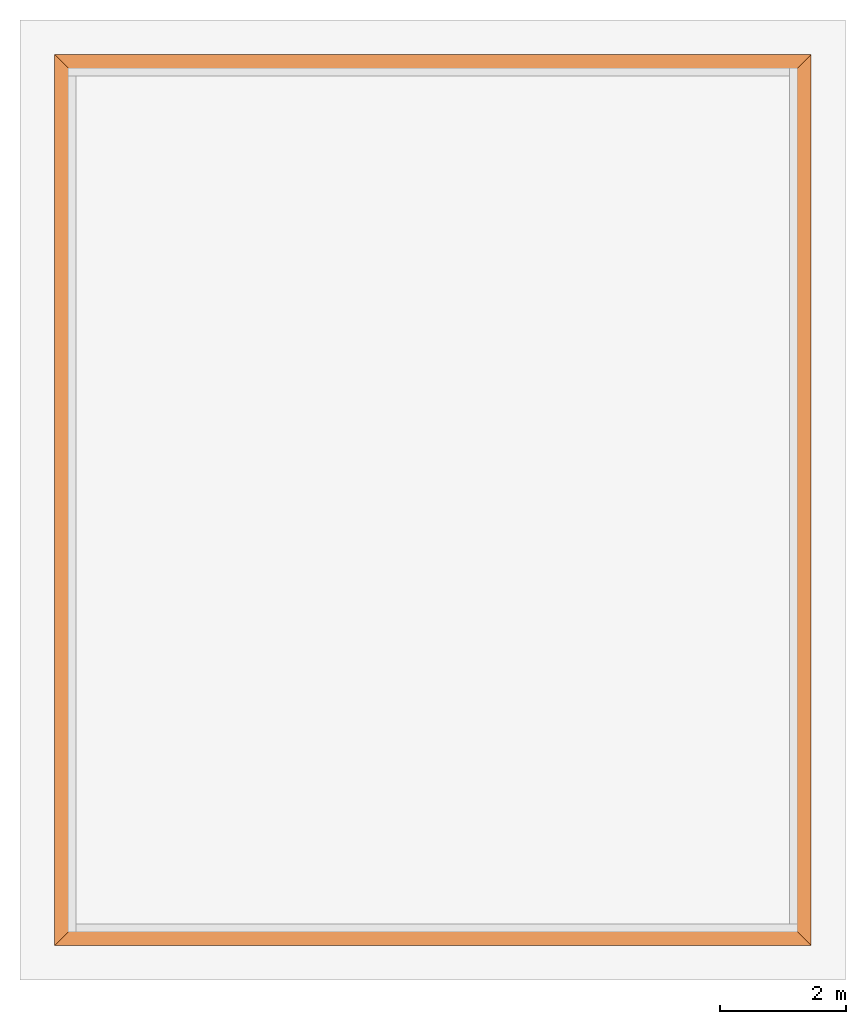
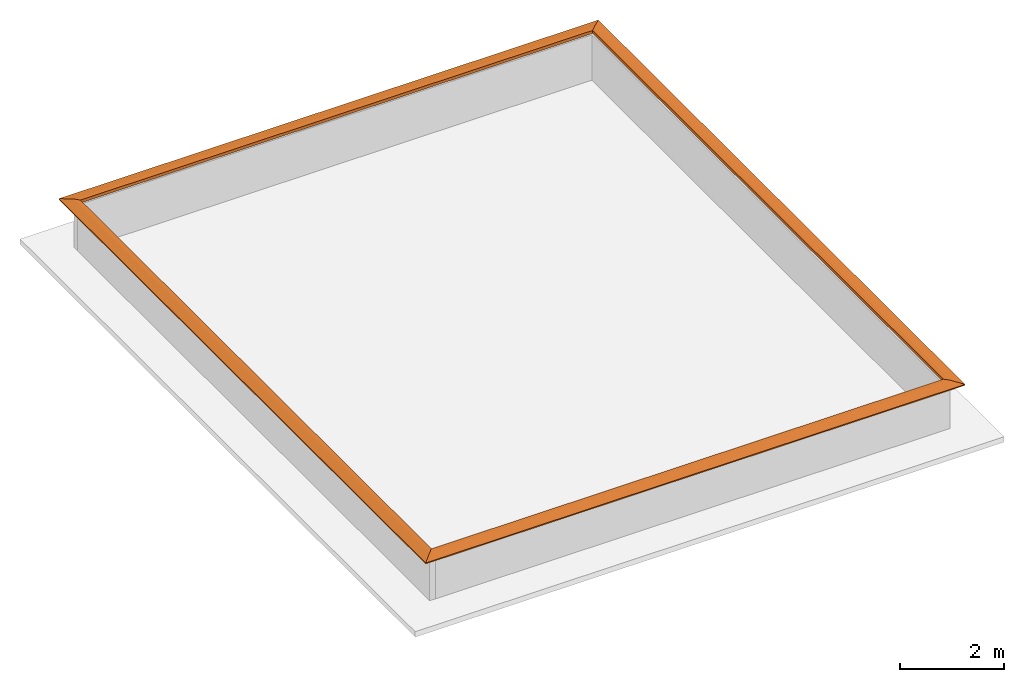
# One storey, part 2 of 2: 4 proxies.
"""IFC2X3 building model written with IfcOpenShell, lengths in feet."""

from ifc_helpers import new_model, entity, si_unit, converted_unit, derived_unit, direction, frame, origin, place, context, subcontext, project, spatial, faceted_brep, material, type_object, element, save


model = new_model("IFC2X3")

# Units and contexts
model_context = context("Model", 3, precision=0.0001, world=origin(), true_north=direction((6.123031769111886e-17, 1.0)))
body_context = subcontext(model_context, "Body", "Model", "MODEL_VIEW")
ifc_project = project(units=[converted_unit("LENGTHUNIT", "FOOT", entity("IfcLengthMeasure", 0.3048), si_unit("LENGTHUNIT", "METRE"), dimensions=[1, 0, 0, 0, 0, 0, 0]), converted_unit("AREAUNIT", "SQUARE FOOT", entity("IfcAreaMeasure", 0.09290304), si_unit("AREAUNIT", "SQUARE_METRE"), dimensions=[2, 0, 0, 0, 0, 0, 0]), converted_unit("VOLUMEUNIT", "CUBIC FOOT", entity("IfcVolumeMeasure", 0.028316846592000004), si_unit("VOLUMEUNIT", "CUBIC_METRE"), dimensions=[3, 0, 0, 0, 0, 0, 0]), converted_unit("PLANEANGLEUNIT", "DEGREE", entity("IfcPlaneAngleMeasure", 0.017453292519943278), si_unit("PLANEANGLEUNIT", "RADIAN"), dimensions=[0, 0, 0, 0, 0, 0, 0]), si_unit("MASSUNIT", "GRAM", prefix="KILO"), derived_unit("MASSDENSITYUNIT", [(si_unit("MASSUNIT", "GRAM", prefix="KILO"), 1), (si_unit("LENGTHUNIT", "METRE"), -3)]), derived_unit("IONCONCENTRATIONUNIT", [(si_unit("MASSUNIT", "GRAM", prefix="KILO"), 1), (si_unit("LENGTHUNIT", "METRE"), -3)]), derived_unit("MOMENTOFINERTIAUNIT", [(si_unit("LENGTHUNIT", "METRE"), 4)]), si_unit("TIMEUNIT", "SECOND"), si_unit("FREQUENCYUNIT", "HERTZ"), si_unit("THERMODYNAMICTEMPERATUREUNIT", "DEGREE_CELSIUS"), derived_unit("THERMALTRANSMITTANCEUNIT", [(si_unit("MASSUNIT", "GRAM", prefix="KILO"), 1), (si_unit("THERMODYNAMICTEMPERATUREUNIT", "KELVIN"), -1), (si_unit("TIMEUNIT", "SECOND"), -3)]), derived_unit("THERMALCONDUCTANCEUNIT", [(si_unit("MASSUNIT", "GRAM", prefix="KILO"), 1), (si_unit("THERMODYNAMICTEMPERATUREUNIT", "KELVIN"), -1), (si_unit("TIMEUNIT", "SECOND"), -3), (si_unit("LENGTHUNIT", "METRE"), 1)]), derived_unit("VOLUMETRICFLOWRATEUNIT", [(si_unit("LENGTHUNIT", "METRE"), 3), (si_unit("TIMEUNIT", "SECOND"), -1)]), derived_unit("MASSFLOWRATEUNIT", [(si_unit("MASSUNIT", "GRAM", prefix="KILO"), 1), (si_unit("TIMEUNIT", "SECOND"), -1)]), derived_unit("ROTATIONALFREQUENCYUNIT", [(si_unit("TIMEUNIT", "SECOND"), -1)]), si_unit("ELECTRICCURRENTUNIT", "AMPERE"), si_unit("ELECTRICVOLTAGEUNIT", "VOLT"), si_unit("POWERUNIT", "WATT"), converted_unit("FORCEUNIT", "KIP", entity("IfcForceMeasure", 2.088543423315013e-05), si_unit("FORCEUNIT", "NEWTON"), dimensions=[1, 1, -2, 0, 0, 0, 0]), si_unit("ILLUMINANCEUNIT", "LUX"), si_unit("LUMINOUSFLUXUNIT", "LUMEN"), si_unit("LUMINOUSINTENSITYUNIT", "CANDELA"), si_unit("ENERGYUNIT", "JOULE"), derived_unit("USERDEFINED", [(si_unit("MASSUNIT", "GRAM", prefix="KILO"), -1), (si_unit("LENGTHUNIT", "METRE"), -2), (si_unit("TIMEUNIT", "SECOND"), 3), (si_unit("LUMINOUSFLUXUNIT", "LUMEN"), 1)]), derived_unit("USERDEFINED", [(si_unit("MASSUNIT", "GRAM", prefix="KILO"), 1), (si_unit("TIMEUNIT", "SECOND"), -3), (si_unit("LENGTHUNIT", "METRE"), 3), (si_unit("ELECTRICCURRENTUNIT", "AMPERE"), -2)]), derived_unit("SOUNDPOWERUNIT", [(si_unit("MASSUNIT", "GRAM", prefix="KILO"), 1), (si_unit("TIMEUNIT", "SECOND"), -3), (si_unit("LENGTHUNIT", "METRE"), 2)]), derived_unit("SOUNDPRESSUREUNIT", [(si_unit("MASSUNIT", "GRAM", prefix="KILO"), 1), (si_unit("LENGTHUNIT", "METRE"), -1), (si_unit("TIMEUNIT", "SECOND"), -2)]), derived_unit("LINEARVELOCITYUNIT", [(si_unit("LENGTHUNIT", "METRE"), 1), (si_unit("TIMEUNIT", "SECOND"), -1)]), si_unit("PRESSUREUNIT", "PASCAL"), derived_unit("USERDEFINED", [(si_unit("MASSUNIT", "GRAM", prefix="KILO"), 1), (si_unit("LENGTHUNIT", "METRE"), -2), (si_unit("TIMEUNIT", "SECOND"), -2)]), derived_unit("LINEARFORCEUNIT", [(si_unit("MASSUNIT", "GRAM", prefix="KILO"), 1), (si_unit("TIMEUNIT", "SECOND"), -2)]), derived_unit("PLANARFORCEUNIT", [(si_unit("MASSUNIT", "GRAM", prefix="KILO"), 1), (si_unit("LENGTHUNIT", "METRE"), -1), (si_unit("TIMEUNIT", "SECOND"), -2)]), derived_unit("SPECIFICHEATCAPACITYUNIT", [(si_unit("THERMODYNAMICTEMPERATUREUNIT", "KELVIN"), -1), (si_unit("LENGTHUNIT", "METRE"), 2), (si_unit("TIMEUNIT", "SECOND"), -2)]), derived_unit("HEATFLUXDENSITYUNIT", [(si_unit("MASSUNIT", "GRAM", prefix="KILO"), 1), (si_unit("TIMEUNIT", "SECOND"), -3)]), derived_unit("HEATINGVALUEUNIT", [(si_unit("LENGTHUNIT", "METRE"), 2), (si_unit("TIMEUNIT", "SECOND"), -2)]), derived_unit("VAPORPERMEABILITYUNIT", [(si_unit("LENGTHUNIT", "METRE"), -1), (si_unit("TIMEUNIT", "SECOND"), 1)]), derived_unit("DYNAMICVISCOSITYUNIT", [(si_unit("MASSUNIT", "GRAM", prefix="KILO"), 1), (si_unit("TIMEUNIT", "SECOND"), -1), (si_unit("LENGTHUNIT", "METRE"), -1)]), derived_unit("THERMALEXPANSIONCOEFFICIENTUNIT", [(si_unit("THERMODYNAMICTEMPERATUREUNIT", "KELVIN"), -1)]), derived_unit("MODULUSOFELASTICITYUNIT", [(si_unit("MASSUNIT", "GRAM", prefix="KILO"), 1), (si_unit("LENGTHUNIT", "METRE"), -1), (si_unit("TIMEUNIT", "SECOND"), -2)]), derived_unit("ISOTHERMALMOISTURECAPACITYUNIT", [(si_unit("LENGTHUNIT", "METRE"), 3), (si_unit("MASSUNIT", "GRAM", prefix="KILO"), -1)]), derived_unit("MOISTUREDIFFUSIVITYUNIT", [(si_unit("TIMEUNIT", "SECOND"), -1), (si_unit("LENGTHUNIT", "METRE"), 2)]), derived_unit("MASSPERLENGTHUNIT", [(si_unit("MASSUNIT", "GRAM", prefix="KILO"), 1), (si_unit("LENGTHUNIT", "METRE"), -1)]), derived_unit("THERMALRESISTANCEUNIT", [(si_unit("MASSUNIT", "GRAM", prefix="KILO"), -1), (si_unit("TIMEUNIT", "SECOND"), 3), (si_unit("THERMODYNAMICTEMPERATUREUNIT", "KELVIN"), 1)]), derived_unit("ACCELERATIONUNIT", [(si_unit("LENGTHUNIT", "METRE"), 1), (si_unit("TIMEUNIT", "SECOND"), -2)]), derived_unit("ANGULARVELOCITYUNIT", [(si_unit("TIMEUNIT", "SECOND"), -1), (si_unit("PLANEANGLEUNIT", "RADIAN"), 1)]), derived_unit("LINEARSTIFFNESSUNIT", [(si_unit("MASSUNIT", "GRAM", prefix="KILO"), 1), (si_unit("TIMEUNIT", "SECOND"), -2)]), derived_unit("WARPINGCONSTANTUNIT", [(si_unit("LENGTHUNIT", "METRE"), 6)]), derived_unit("LINEARMOMENTUNIT", [(si_unit("MASSUNIT", "GRAM", prefix="KILO"), 1), (si_unit("LENGTHUNIT", "METRE"), 1), (si_unit("TIMEUNIT", "SECOND"), -2)]), derived_unit("TORQUEUNIT", [(si_unit("MASSUNIT", "GRAM", prefix="KILO"), 1), (si_unit("LENGTHUNIT", "METRE"), 2), (si_unit("TIMEUNIT", "SECOND"), -2)])], contexts=[model_context])

# Site, building, storey
site_placement = place(None, origin())
site = spatial("IfcSite", under=ifc_project, at=site_placement, CompositionType="ELEMENT")
building_placement = place(site_placement, origin())
building = spatial("IfcBuilding", under=site, at=building_placement, CompositionType="ELEMENT")
storey_placement = place(building_placement, frame((0.0, 0.0, 28.25000000000186)))
storey = spatial("IfcBuildingStorey", under=building, at=storey_placement, Name="Third Floor", CompositionType="ELEMENT", Elevation=28.25000000000186)

# Proxies
ifc_material = material(Name="Wood - Stained")
building_element_proxy_type_1 = type_object("IfcBuildingElementProxyType", Name="441129", PredefinedType="NOTDEFINED")
proxy_1_placement = place(storey_placement, frame((9.17656135249652, -5.143328180582902, 3.5)))
element("IfcBuildingElementProxy", 1, at=proxy_1_placement, inside=storey, type_object=building_element_proxy_type_1, material=ifc_material, Name="441129", context=body_context, shape_type="Brep", body=[
    faceted_brep([(1.0, 0.0, 0.22916666666666785), (0.6979166666666661, 0.3020833333333339, 0.2291666666666643), (0.0, 1.0, 0.08333333333333215), (0.0, 1.0, 0.0), (1.0, 0.0, 0.0), (38.395833333333485, 0.0, 0.22916666666666785), (38.395833333333485, 0.0, 0.0), (39.39583333333348, 1.0, 0.0), (39.39583333333348, 1.0, 0.08333333333333215), (38.69791666666681, 0.3020833333333339, 0.22916666666666785)], [[[0, 1, 2, 3, 4]], [[5, 6, 7, 8, 9]], [[1, 0, 5, 9]], [[2, 1, 9, 8]], [[3, 2, 8, 7]], [[4, 3, 7, 6]], [[0, 4, 6, 5]]]),
])
building_element_proxy_type_2 = type_object("IfcBuildingElementProxyType", Name="441130", PredefinedType="NOTDEFINED")
proxy_2_placement = place(storey_placement, frame((9.17656135249652, -50.53916151391643, 3.5)))
element("IfcBuildingElementProxy", 2, at=proxy_2_placement, inside=storey, type_object=building_element_proxy_type_2, material=ifc_material, Name="441130", context=body_context, shape_type="Brep", body=[
    faceted_brep([(1.0, 1.0, 0.22916666666666785), (0.6979166666666661, 0.6979166666666643, 0.2291666666666643), (0.0, 0.0, 0.08333333333333215), (0.0, 0.0, 0.0), (1.0, 1.0, 0.0), (1.0, 45.39583333333353, 0.22916666666666785), (1.0, 45.39583333333353, 0.0), (0.0, 46.39583333333353, 0.0), (0.0, 46.39583333333353, 0.08333333333333215), (0.6979166666666679, 45.69791666666686, 0.22916666666666785)], [[[0, 1, 2, 3, 4]], [[5, 6, 7, 8, 9]], [[1, 0, 5, 9]], [[2, 1, 9, 8]], [[3, 2, 8, 7]], [[4, 3, 7, 6]], [[0, 4, 6, 5]]]),
])
building_element_proxy_type_3 = type_object("IfcBuildingElementProxyType", Name="441131", PredefinedType="NOTDEFINED")
proxy_3_placement = place(storey_placement, frame((9.17656135249652, -50.53916151391643, 3.5)))
element("IfcBuildingElementProxy", 3, at=proxy_3_placement, inside=storey, type_object=building_element_proxy_type_3, material=ifc_material, Name="441131", context=body_context, shape_type="Brep", body=[
    faceted_brep([(38.39583333333347, 1.0, 0.22916666666666785), (38.697916666666806, 0.6979166666666643, 0.2291666666666643), (39.39583333333347, 0.0, 0.08333333333333215), (39.39583333333347, 0.0, 0.0), (38.39583333333347, 1.0, 0.0), (1.0, 1.0, 0.22916666666666785), (1.0, 1.0, 0.0), (0.0, 0.0, 0.0), (0.0, 0.0, 0.08333333333333215), (0.6979166666666643, 0.6979166666666643, 0.22916666666666785)], [[[0, 1, 2, 3, 4]], [[5, 6, 7, 8, 9]], [[1, 0, 5, 9]], [[2, 1, 9, 8]], [[3, 2, 8, 7]], [[4, 3, 7, 6]], [[0, 4, 6, 5]]]),
])
building_element_proxy_type_4 = type_object("IfcBuildingElementProxyType", Name="441132", PredefinedType="NOTDEFINED")
proxy_4_placement = place(storey_placement, frame((47.57239468582999, -50.53916151391643, 3.5)))
element("IfcBuildingElementProxy", 4, at=proxy_4_placement, inside=storey, type_object=building_element_proxy_type_4, material=ifc_material, Name="441132", context=body_context, shape_type="Brep", body=[
    faceted_brep([(0.0, 45.39583333333353, 0.22916666666666785), (0.3020833333333428, 45.69791666666686, 0.2291666666666643), (1.0, 46.39583333333353, 0.08333333333333215), (1.0, 46.39583333333353, 0.0), (0.0, 45.39583333333353, 0.0), (0.0, 1.0, 0.22916666666666785), (0.0, 1.0, 0.0), (1.0, 0.0, 0.0), (1.0, 0.0, 0.08333333333333215), (0.3020833333333357, 0.6979166666666643, 0.22916666666666785)], [[[0, 1, 2, 3, 4]], [[5, 6, 7, 8, 9]], [[1, 0, 5, 9]], [[2, 1, 9, 8]], [[3, 2, 8, 7]], [[4, 3, 7, 6]], [[0, 4, 6, 5]]]),
])

save(model, "model.ifc")
